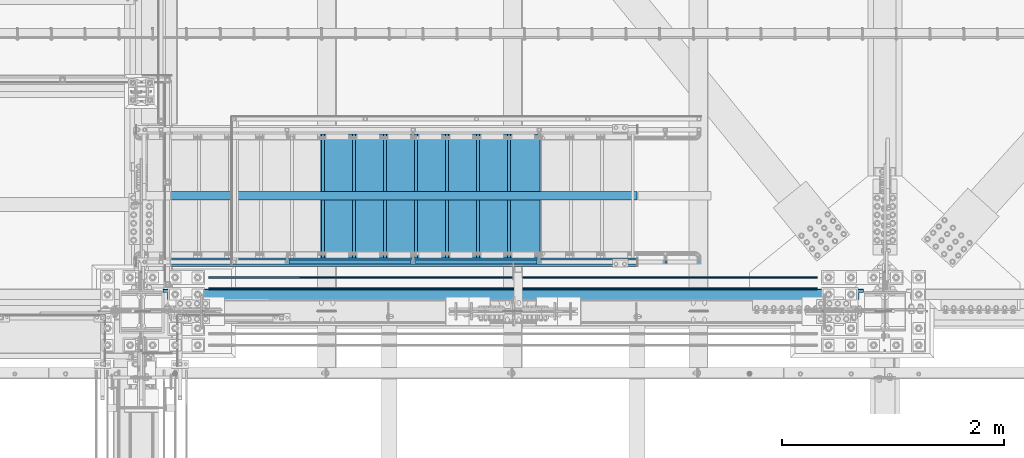
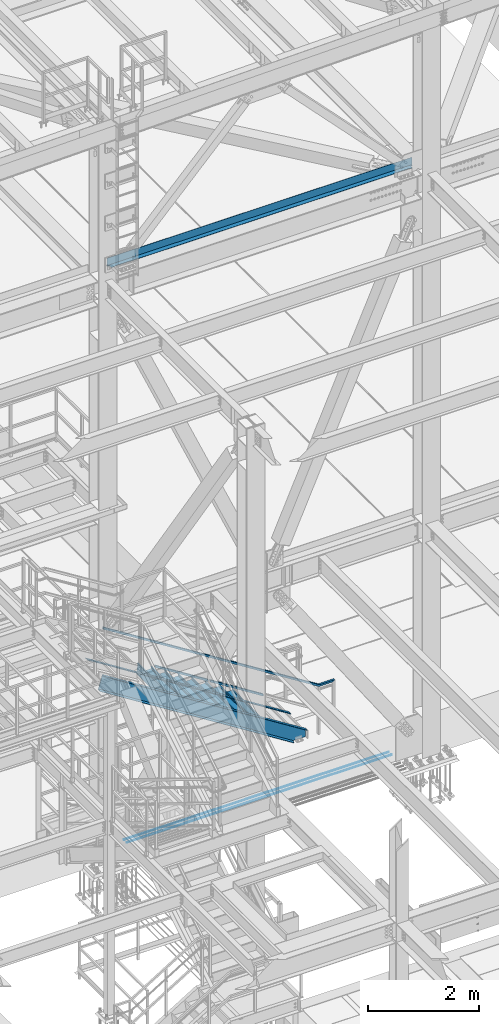
# One storey, part 1789 of 3843: 11 beams, 4 members, 6 elements without a shape of their own.
"""IFC2X3 building model written with IfcOpenShell, lengths in millimetres."""

import ifcopenshell
import ifcopenshell.guid

model = None  # the IFC model being written
_history = None  # IfcOwnerHistory: only IFC2X3 demands one
_inside = {}  # id of a spatial element -> (the spatial element, [elements in it])
_under = {}  # id of a project, library or spatial element -> (it, [spatial elements below it])
_declared = {}  # id of a project -> (the project, [libraries it declares])
_typed = {}  # id of a type object -> (the type object, [elements of that type])
_made_of = {}  # id of a material, layer set ... -> (it, [elements and type objects made of it])


def new_model(schema):
    """Start an empty IFC model of exactly this schema.

    Asked for "IFC4X3", IfcOpenShell would pick the latest addendum, in which some entities
    have other attributes; the version numbers below select the first issue.
    IFC2X3 requires an IfcOwnerHistory on every rooted entity: one is made here for all.
    """
    global model, _history
    if schema == "IFC4X3":
        model = ifcopenshell.file(schema_version=(4, 3, 0, 0))
    else:
        model = ifcopenshell.file(schema=schema)
    _inside.clear()
    _under.clear()
    _declared.clear()
    _typed.clear()
    _made_of.clear()
    _history = None
    if model.schema == "IFC2X3":
        org = make("IfcOrganization", Name="unknown")
        user = make(
            "IfcPersonAndOrganization",
            ThePerson=make("IfcPerson", FamilyName="unknown"),
            TheOrganization=org,
        )
        app = make(
            "IfcApplication",
            ApplicationDeveloper=org,
            Version="unknown",
            ApplicationFullName="unknown",
            ApplicationIdentifier="unknown",
        )
        _history = make(
            "IfcOwnerHistory",
            OwningUser=user,
            OwningApplication=app,
            ChangeAction="ADDED",
            CreationDate=0,
        )
    return model


def make(cls, **values):
    """One entity of the class cls with the attributes given. An attribute that is None is left unset."""
    return model.create_entity(
        cls, **{name: value for name, value in values.items() if value is not None}
    )


def rooted(cls, **values):
    """An entity with a GlobalId (a new one), such as an element, a storey or a relation."""
    return make(cls, GlobalId=ifcopenshell.guid.new(), OwnerHistory=_history, **values)


def si_unit(unit_type, name, prefix=None):
    """IfcSIUnit, for example si_unit("LENGTHUNIT", "METRE", prefix="MILLI")."""
    return make("IfcSIUnit", UnitType=unit_type, Prefix=prefix, Name=name)


def assignment(units):
    """IfcUnitAssignment: the units of a project."""
    return None if units is None else make("IfcUnitAssignment", Units=units)


def point(xyz):
    """IfcCartesianPoint."""
    return None if xyz is None else make("IfcCartesianPoint", Coordinates=xyz)


def direction(xyz):
    """IfcDirection."""
    return None if xyz is None else make("IfcDirection", DirectionRatios=xyz)


def frame(location, z_axis=None, x_axis=None):
    """IfcAxis2Placement3D, a coordinate frame: its origin and axes. An axis left out is left unset."""
    return make(
        "IfcAxis2Placement3D",
        Location=point(location),
        Axis=direction(z_axis),
        RefDirection=direction(x_axis),
    )


def origin_with_axes():
    """The frame at (0, 0, 0) with the z axis (0, 0, 1) and the x axis (1, 0, 0) written out."""
    return frame((0.0, 0.0, 0.0), z_axis=(0.0, 0.0, 1.0), x_axis=(1.0, 0.0, 0.0))


def place(relative_to, where):
    """IfcLocalPlacement: puts the frame where relative to a parent placement (None: the world)."""
    return make(
        "IfcLocalPlacement", PlacementRelTo=relative_to, RelativePlacement=where
    )


def context(
    kind, dimensions, precision=None, world=None, true_north=None, identifier=None
):
    """IfcGeometricRepresentationContext, for example the 3D "Model" context."""
    return make(
        "IfcGeometricRepresentationContext",
        ContextIdentifier=identifier,
        ContextType=kind,
        CoordinateSpaceDimension=dimensions,
        Precision=precision,
        WorldCoordinateSystem=world,
        TrueNorth=true_north,
    )


def subcontext(parent, identifier, kind, view, scale=None):
    """IfcGeometricRepresentationSubContext, for example "Body" below "Model"."""
    return make(
        "IfcGeometricRepresentationSubContext",
        ContextIdentifier=identifier,
        ContextType=kind,
        ParentContext=parent,
        TargetScale=scale,
        TargetView=view,
    )


def project(units=None, contexts=None):
    """IfcProject with its units and contexts."""
    return rooted(
        "IfcProject",
        Name="project",
        RepresentationContexts=contexts,
        UnitsInContext=assignment(units),
    )


def spatial(cls, under=None, at=None, **own):
    """A site, building, storey or space (cls), placed at a placement, below another one or the project."""
    s = rooted(cls, ObjectPlacement=at, **own)
    if under is not None:
        _under.setdefault(under.id(), (under, []))[1].append(s)
    return s


def faces_of(points, faces, orient=None, outer=None):
    """IfcFace entities. A face is a list of loops; a loop is a list of indices into points, from 0.

    orient and outer hold one flag for each loop. By default every Orientation is true, the
    first loop of a face is its IfcFaceOuterBound and the others are IfcFaceBound.
    """
    made = []
    for i, loops in enumerate(faces):
        bounds = []
        for j, loop in enumerate(loops):
            is_outer = j == 0 if outer is None else outer[i][j]
            bounds.append(
                make(
                    "IfcFaceOuterBound" if is_outer else "IfcFaceBound",
                    Bound=make("IfcPolyLoop", Polygon=[points[k] for k in loop]),
                    Orientation=True if orient is None else orient[i][j],
                )
            )
        made.append(make("IfcFace", Bounds=bounds))
    return made


def faceted_brep(points, faces, orient=None, outer=None, voids=None):
    """IfcFacetedBrep: a solid bounded by flat faces; with voids (closed shells), ...WithVoids."""
    shared = [point(p) for p in points]
    hull = make("IfcClosedShell", CfsFaces=faces_of(shared, faces, orient, outer))
    if voids is None:
        return make("IfcFacetedBrep", Outer=hull)
    return make(
        "IfcFacetedBrepWithVoids",
        Outer=hull,
        Voids=[
            make(cls, CfsFaces=faces_of(shared, fs, o, b)) for cls, fs, o, b in voids
        ],
    )


def shape(context_of_items, identifier, shape_type, items):
    """IfcShapeRepresentation: the items that make up one representation, for example the "Body"."""
    return make(
        "IfcShapeRepresentation",
        ContextOfItems=context_of_items,
        RepresentationIdentifier=identifier,
        RepresentationType=shape_type,
        Items=items,
    )


def material(Name=None, Category=None):
    """IfcMaterial."""
    return make("IfcMaterial", Name=Name, Category=Category)


def made_of(thing, what):
    """Note that an element or type object is made of a material, layer set ...; save() writes the relation."""
    if what is not None:
        _made_of.setdefault(what.id(), (what, []))[1].append(thing)
    return thing


def type_object(cls, material=None, **own):
    """A type object (cls), such as IfcWallType, which elements share."""
    return made_of(rooted(cls, **own), material)


def element(
    cls,
    number,
    at=None,
    inside=None,
    cuts=None,
    type_object=None,
    material=None,
    context=None,
    identifier="Body",
    shape_type=None,
    held_by="IfcProductDefinitionShape",
    body=None,
    shapes=None,
    **own,
):
    """One element of the class cls, such as IfcWall. Its Tag is "e" and its number.

    at: its placement. inside: the storey or other place that contains it. cuts: it is an
    opening in that element (IfcRelVoidsElement). A single representation is given by context,
    identifier, shape_type and body (its items); several are given by shapes. held_by: the class
    of the entity that holds the representations. save() writes the other relations.
    """
    e = rooted(cls, Tag="e%d" % number, ObjectPlacement=at, **own)
    if body is not None:
        shapes = [shape(context, identifier, shape_type, body)]
    if shapes is not None:
        e.Representation = make(held_by, Representations=shapes)
    if inside is not None:
        _inside.setdefault(inside.id(), (inside, []))[1].append(e)
    if cuts is not None:
        rooted(
            "IfcRelVoidsElement", RelatingBuildingElement=cuts, RelatedOpeningElement=e
        )
    if type_object is not None:
        _typed.setdefault(type_object.id(), (type_object, []))[1].append(e)
    return made_of(e, material)


def aggregate(whole, parts):
    """IfcRelAggregates: a whole, such as a stair, and the parts it consists of."""
    return rooted("IfcRelAggregates", RelatingObject=whole, RelatedObjects=parts)


def save(model, path):
    """Write the relations noted so far, then the file.

    IfcRelAggregates (storeys below a building ...), IfcRelContainedInSpatialStructure (elements
    in a storey), IfcRelDefinesByType, IfcRelAssociatesMaterial and IfcRelDeclares: one each for
    every whole, place, type object, material and project.
    """
    for whole, parts in _under.values():
        aggregate(whole, parts)
    for where, things in _inside.values():
        rooted(
            "IfcRelContainedInSpatialStructure",
            RelatedElements=things,
            RelatingStructure=where,
        )
    for kind, things in _typed.values():
        rooted("IfcRelDefinesByType", RelatedObjects=things, RelatingType=kind)
    for what, things in _made_of.values():
        rooted("IfcRelAssociatesMaterial", RelatedObjects=things, RelatingMaterial=what)
    for by, libraries in _declared.values():
        rooted("IfcRelDeclares", RelatingContext=by, RelatedDefinitions=libraries)
    model.write(path)


model = new_model("IFC2X3")

# Units and contexts
model_context = context("Model", 3, precision=1e-05, world=origin_with_axes())
body_context = subcontext(model_context, "Body", "Model", "MODEL_VIEW")
ifc_project = project(units=[si_unit("LENGTHUNIT", "METRE", prefix="MILLI"), si_unit("AREAUNIT", "SQUARE_METRE"), si_unit("VOLUMEUNIT", "CUBIC_METRE"), si_unit("MASSUNIT", "GRAM", prefix="KILO"), si_unit("TIMEUNIT", "SECOND"), si_unit("PLANEANGLEUNIT", "RADIAN"), si_unit("SOLIDANGLEUNIT", "STERADIAN"), si_unit("THERMODYNAMICTEMPERATUREUNIT", "DEGREE_CELSIUS"), si_unit("LUMINOUSINTENSITYUNIT", "LUMEN")], contexts=[model_context])

# Site, building, storey
site_placement = place(None, origin_with_axes())
site = spatial("IfcSite", under=ifc_project, at=site_placement, CompositionType="ELEMENT")
building_placement = place(site_placement, origin_with_axes())
building = spatial("IfcBuilding", under=site, at=building_placement, Name="Undefined", CompositionType="ELEMENT")
storey_placement = place(building_placement, origin_with_axes())
storey = spatial("IfcBuildingStorey", under=building, at=storey_placement, Name="Undefined", CompositionType="ELEMENT", Elevation=0.0)

# Assembly, beam, members
assembly_1_placement = place(storey_placement, origin_with_axes())
assembly_1 = element("IfcElementAssembly", 1, at=assembly_1_placement, inside=storey, Name="RAIL", AssemblyPlace="NOTDEFINED", PredefinedType="RIGID_FRAME")
ifc_material_1 = material()
beam_type_1 = type_object("IfcBeamType", Name="HSS1-1/2X1-1/2X1/4", PredefinedType="NOTDEFINED")
beam_1_placement = place(assembly_1_placement, frame((56184.7999995645, 26060.40000005, 34366.2000003071), z_axis=(-0.533450437959022, 0.0, -0.845831324935018), x_axis=(0.845831324935018, 0.0, -0.533450437959022)))
beam_1 = element("IfcBeam", 2, at=beam_1_placement, type_object=beam_type_1, material=ifc_material_1, Name="RAIL", ObjectType="HSS1-1/2X1-1/2X1/4", context=body_context, shape_type="Brep", body=[
    faceted_brep([(-5.50550328531972, 19.0499992350015, -19.0499992347177), (-5.50550328531972, -19.0499992350015, -19.0499992347177), (5.50550332753846, -19.0499992350015, 19.0499992347031), (5.50550332753846, 19.0499992350015, 19.0499992347031), (-3.67033547026585, 12.6999993300014, -12.6999993298159), (3.67033551248824, 12.6999993300014, 12.6999993297941), (3.67033551248824, -12.6999993300014, 12.6999993297941), (-3.67033547026585, -12.6999993300014, -12.6999993298159), (5290.72002363061, -19.0499992350015, 19.0499989655946), (5290.72002363061, 19.0499992350015, 19.0499989655946), (5279.70901704712, 19.0499992350015, -19.0499995038263), (5279.70901704712, -19.0499992350015, -19.0499995038263), (5281.54418485728, -12.6999993300014, -12.6999995989245), (5281.54418485728, 12.6999993300014, -12.6999995989245), (5288.88485582045, 12.6999993300014, 12.6999990606928), (5288.88485582045, -12.6999993300014, 12.6999990606928), (5548.97476379322, 19.0499992350015, -188.871010251023), (5548.97476379322, -19.0499992350015, -188.871010251023), (5537.07305247765, -19.0499992350015, -136.320377196243), (5537.07305247765, 19.0499992350015, -136.320377196243), (5546.99114519064, -12.6999993300014, -180.112571187878), (5546.99114519064, 12.6999993300014, -180.112571187878), (5539.05667108022, 12.6999993300014, -145.078816259382), (5539.05667108022, -12.6999993300014, -145.078816259382)], [[[0, 1, 2, 3], [4, 5, 6, 7]], [[3, 2, 8, 9]], [[1, 0, 10, 11]], [[4, 7, 12, 13]], [[6, 5, 14, 15]], [[11, 10, 16, 17]], [[8, 2, 1, 11, 17, 18]], [[9, 8, 18, 19]], [[10, 0, 3, 9, 19, 16]], [[13, 12, 20, 21]], [[14, 5, 4, 13, 21, 22]], [[15, 14, 22, 23]], [[12, 7, 6, 15, 23, 20]], [[19, 18, 17, 16], [22, 21, 20, 23]]]),
])
member_type_1 = type_object("IfcMemberType", Name="HSS1-1/2X1-1/2X1/4", PredefinedType="NOTDEFINED")
member_1_placement = place(assembly_1_placement, frame((58381.8999999823, 26060.40000005, 32447.1289770913), z_axis=(0.533450437959022, 0.0, 0.845831324935018), x_axis=(-0.845831324935018, 0.0, 0.533450437959022)))
member_1 = element("IfcMember", 3, at=member_1_placement, type_object=member_type_1, material=ifc_material_1, Name="RAIL", ObjectType="HSS1-1/2X1-1/2X1/4", context=body_context, shape_type="Brep", body=[
    faceted_brep([(1333.31811817363, -19.0500003825, 19.049999236413), (1309.28914186234, -19.0499992350015, -19.0499992335972), (1309.28914186234, 19.0499992350015, -19.0499992335972), (1333.31811817363, 19.0499992350015, 19.049999236413), (1329.31328868799, -12.6999993300014, 12.6999993314093), (1329.31328868799, 12.6999993300014, 12.6999993314093), (1313.29397134907, 12.6999993300014, -12.6999993285935), (1313.29397134907, -12.6999993300014, -12.6999993285935), (10.507732870894, 19.0499992350015, -19.049999235016), (34.5367091819608, 19.0499992350015, 19.0499992349214), (34.5367091819608, -19.0500003825, 19.0499992349214), (10.507732870894, -19.0499992350015, -19.049999235016), (30.5318796958745, -12.6999993300014, 12.699999329925), (14.5125623569802, -12.6999993300014, -12.6999993300269), (14.5125623569802, 12.6999993300014, -12.6999993300269), (30.5318796958745, 12.6999993300014, 12.699999329925)], [[[0, 1, 2, 3], [4, 5, 6, 7]], [[8, 9, 3, 2]], [[9, 10, 0, 3]], [[10, 11, 1, 0]], [[11, 8, 2, 1]], [[10, 9, 8, 11], [12, 13, 14, 15]], [[13, 12, 4, 7]], [[14, 13, 7, 6]], [[15, 14, 6, 5]], [[12, 15, 5, 4]]]),
])
member_2_placement = place(assembly_1_placement, frame((59518.5499999929, 26060.40000005, 31730.2644883423), z_axis=(0.533450437959022, 0.0, 0.845831324935018), x_axis=(-0.845831324935018, 0.0, 0.533450437959022)))
member_2 = element("IfcMember", 4, at=member_2_placement, type_object=member_type_1, material=ifc_material_1, Name="RAIL", ObjectType="HSS1-1/2X1-1/2X1/4", context=body_context, shape_type="Brep", body=[
    faceted_brep([(1333.31811817363, -19.0500003825, 19.049999236413), (1309.28914186234, -19.0499992350015, -19.0499992335972), (1309.28914186234, 19.0499992350015, -19.0499992335972), (1333.31811817363, 19.0499992350015, 19.049999236413), (1329.31328868799, -12.6999993300014, 12.6999993314093), (1329.31328868799, 12.6999993300014, 12.6999993314093), (1313.29397134907, 12.6999993300014, -12.6999993285935), (1313.29397134907, -12.6999993300014, -12.6999993285935), (10.507732870894, 19.0499992350015, -19.049999235016), (34.5367091819608, 19.0499992350015, 19.0499992349214), (34.5367091819608, -19.0500003825, 19.0499992349214), (10.507732870894, -19.0499992350015, -19.049999235016), (30.5318796958745, -12.6999993300014, 12.699999329925), (14.5125623569802, -12.6999993300014, -12.6999993300269), (14.5125623569802, 12.6999993300014, -12.6999993300269), (30.5318796958745, 12.6999993300014, 12.699999329925)], [[[0, 1, 2, 3], [4, 5, 6, 7]], [[8, 9, 3, 2]], [[9, 10, 0, 3]], [[10, 11, 1, 0]], [[11, 8, 2, 1]], [[10, 9, 8, 11], [12, 13, 14, 15]], [[13, 12, 4, 7]], [[14, 13, 7, 6]], [[15, 14, 6, 5]], [[12, 15, 5, 4]]]),
])
aggregate(assembly_1, [beam_1, member_1, member_2])

# Assembly, member
assembly_2_placement = place(storey_placement, origin_with_axes())
assembly_2 = element("IfcElementAssembly", 5, at=assembly_2_placement, inside=storey, Name="STAIR", AssemblyPlace="NOTDEFINED", PredefinedType="RIGID_FRAME")
ifc_material_2 = material(Name="STEEL/A36")
member_type_2 = type_object("IfcMemberType", Name="C12X20.7", PredefinedType="NOTDEFINED")
member_3_placement = place(assembly_2_placement, frame((56110.842824609, 26060.4000000759, 33195.8953060768), z_axis=(0.533450437959022, 0.0, 0.845831324935018), x_axis=(0.845831324935018, 0.0, -0.533450437959022)))
member_3 = element("IfcMember", 6, at=member_3_placement, type_object=member_type_2, material=ifc_material_2, Name="STAIR", ObjectType="C12X20.7", context=body_context, shape_type="Brep", body=[
    faceted_brep([(88.0880557814089, -38.0999999999985, -152.400000000001), (86.2521538732108, -38.0999999999985, -146.047460000002), (82.9654600282593, 30.1624999999985, -134.674927499997), (5.12259516357881, 30.1624999999985, 134.674927499997), (1.83590131863457, -38.0999999999985, 146.047460000002), (0.0, -38.0999999999985, 152.400000000001), (0.0, 38.0999999999985, 152.400000000001), (88.0880557814089, 38.0999999999985, -152.400000000001), (4825.73530544251, 38.0999999999985, -152.399999990193), (4825.73530544251, -38.0999999999985, -152.399999990193), (4835.807801297, -38.0999999999985, -146.047459990179), (4853.83992489816, 30.1624999999985, -134.674927490145), (5070.93921401628, 30.1624999999985, 2.24564691580599), (4987.41847453906, 30.1624999999985, 134.674927510001), (4980.24602506365, -38.0999999999985, 146.047460009984), (4976.23959358582, -38.0999999999985, 152.400000009977), (4976.23959358582, 38.0999999999985, 152.400000009977), (5070.93921401628, 38.0999999999985, 2.24564691580599)], [[[0, 1, 2, 3, 4, 5, 6, 7]], [[0, 7, 8, 9]], [[1, 0, 9, 10]], [[2, 1, 10, 11]], [[3, 2, 11, 12, 13]], [[4, 3, 13, 14]], [[5, 4, 14, 15]], [[6, 5, 15, 16]], [[8, 7, 6, 16, 17]], [[11, 10, 9, 8, 17, 12]], [[16, 15, 14, 13, 12, 17]]]),
])

# Assembly, beam
assembly_3_placement = place(storey_placement, origin_with_axes())
assembly_3 = element("IfcElementAssembly", 7, at=assembly_3_placement, inside=storey, Name="REBAR", AssemblyPlace="NOTDEFINED", PredefinedType="RIGID_FRAME")
ifc_material_3 = material(Name="STEEL/A706-60")
beam_type_2 = type_object("IfcBeamType", Name="#10 REBAR", PredefinedType="NOTDEFINED")
beam_2_placement = place(assembly_3_placement, frame((56540.3999804674, 25920.7000122071, 29687.8375), z_axis=(0.0, 0.0, 1.0), x_axis=(1.0, 0.0, 0.0)))
beam_2 = element("IfcBeam", 8, at=beam_2_placement, type_object=beam_type_2, material=ifc_material_3, Name="REBAR", ObjectType="#10 REBAR", context=body_context, shape_type="Brep", body=[
    faceted_brep([(0.0, -7.9375, 0.0), (0.0, -5.61266007566883, -5.61266007566883), (5486.48749999408, -5.61266007566883, -5.61266007566883), (5486.48749999408, -7.9375, 0.0), (0.0, 0.0, -7.9375), (5486.48749999408, 0.0, -7.9375), (0.0, 5.61266007566883, -5.61266007566883), (5486.48749999408, 5.61266007566883, -5.61266007566883), (0.0, 7.9375, 0.0), (5486.48749999408, 7.9375, 0.0), (0.0, 5.61266007566883, 5.61266007566883), (5486.48749999408, 5.61266007566883, 5.61266007566883), (0.0, 0.0, 7.9375), (5486.48749999408, 0.0, 7.9375), (0.0, -5.61266007566883, 5.61266007566883), (5486.48749999408, -5.61266007566883, 5.61266007566883)], [[[0, 1, 2, 3]], [[1, 4, 5, 2]], [[4, 6, 7, 5]], [[6, 8, 9, 7]], [[8, 10, 11, 9]], [[10, 12, 13, 11]], [[12, 14, 15, 13]], [[14, 0, 3, 15]], [[5, 7, 9, 11, 13, 15, 3, 2]], [[14, 12, 10, 8, 6, 4, 1, 0]]]),
])
aggregate(assembly_3, [beam_2])

assembly_4_placement = place(storey_placement, origin_with_axes())
assembly_4 = element("IfcElementAssembly", 9, at=assembly_4_placement, inside=storey, Name="REBAR", AssemblyPlace="NOTDEFINED", PredefinedType="RIGID_FRAME")
beam_3_placement = place(assembly_4_placement, frame((56540.3999804674, 25819.1000122071, 29687.8375), z_axis=(0.0, 0.0, 1.0), x_axis=(1.0, 0.0, 0.0)))
beam_3 = element("IfcBeam", 10, at=beam_3_placement, type_object=beam_type_2, material=ifc_material_3, Name="REBAR", ObjectType="#10 REBAR", context=body_context, shape_type="Brep", body=[
    faceted_brep([(0.0, -7.9375, 0.0), (0.0, -5.61266007566883, -5.61266007566883), (5486.48749999408, -5.61266007566883, -5.61266007566883), (5486.48749999408, -7.9375, 0.0), (0.0, 0.0, -7.9375), (5486.48749999408, 0.0, -7.9375), (0.0, 5.61266007566883, -5.61266007566883), (5486.48749999408, 5.61266007566883, -5.61266007566883), (0.0, 7.9375, 0.0), (5486.48749999408, 7.9375, 0.0), (0.0, 5.61266007566883, 5.61266007566883), (5486.48749999408, 5.61266007566883, 5.61266007566883), (0.0, 0.0, 7.9375), (5486.48749999408, 0.0, 7.9375), (0.0, -5.61266007566883, 5.61266007566883), (5486.48749999408, -5.61266007566883, 5.61266007566883)], [[[0, 1, 2, 3]], [[1, 4, 5, 2]], [[4, 6, 7, 5]], [[6, 8, 9, 7]], [[8, 10, 11, 9]], [[10, 12, 13, 11]], [[12, 14, 15, 13]], [[14, 0, 3, 15]], [[5, 7, 9, 11, 13, 15, 3, 2]], [[14, 12, 10, 8, 6, 4, 1, 0]]]),
])
aggregate(assembly_4, [beam_3])

# Assembly, member
assembly_5_placement = place(storey_placement, origin_with_axes())
assembly_5 = element("IfcElementAssembly", 11, at=assembly_5_placement, inside=storey, Name="ref.", AssemblyPlace="NOTDEFINED", PredefinedType="RIGID_FRAME")
ifc_material_4 = material(Name="STEEL/Steel_Undefined")
member_type_3 = type_object("IfcMemberType", PredefinedType="NOTDEFINED")
member_4_placement = place(assembly_5_placement, frame((60399.5062948593, 26657.30000005, 30667.5372949473), z_axis=(0.0, -1.0, 0.0), x_axis=(-0.845831324935018, 0.0, 0.533450437959022)))
member_4 = element("IfcMember", 12, at=member_4_placement, type_object=member_type_3, material=ifc_material_4, Name="ref.", context=body_context, shape_type="Brep", body=[
    faceted_brep([(0.0, 3.17500000000291, -38.0999999999985), (0.0, 3.17500000000291, 38.0999999999985), (4976.23959358166, 3.17499999472784, 38.0999999999985), (4976.23959358166, 3.17499999472784, -38.0999999999985), (0.0, -3.17500000000291, 38.0999999999985), (4976.23959358167, -3.17500000526343, 38.0999999999985), (0.0, -3.17500000000291, -38.0999999999985), (4976.23959358167, -3.17500000526343, -38.0999999999985)], [[[0, 1, 2, 3]], [[1, 4, 5, 2]], [[4, 6, 7, 5]], [[6, 0, 3, 7]], [[5, 7, 3, 2]], [[6, 4, 1, 0]]]),
])
aggregate(assembly_5, [member_4])

# Beam
ifc_material_5 = material(Name="STEEL/ASTM A1011")
beam_type_3 = type_object("IfcBeamType", PredefinedType="NOTDEFINED")
beam_4_placement = place(assembly_2_placement, frame((57556.4000000119, 26657.3000000423, 32416.7499999819), z_axis=(0.0, 1.0, 0.0), x_axis=(1.0, 0.0, 0.0)))
beam_4 = element("IfcBeam", 13, at=beam_4_placement, type_object=beam_type_3, material=ifc_material_5, Name="TREAD", context=body_context, shape_type="Brep", body=[
    faceted_brep([(0.0, -1.58750000000146, -558.799999999999), (0.0, -1.58750000000146, 558.799999999999), (0.0, 1.58750000000146, 558.799999999999), (0.0, 1.58750000000146, -558.799999999999), (21.7345275870466, 1.58750000000146, 558.799999999999), (21.7345275870466, 1.58750000000146, -558.799999999999), (25.3999999999942, -1.58750000000146, -558.799999999999), (25.3999999999942, -1.58750000000146, 558.799999999999), (-10.9879949354727, 228.599999999999, 558.799999999999), (-10.9879949354727, 228.599999999999, -558.799999999999), (-7.32252251826139, 225.424999999996, -558.799999999999), (-7.32252251826139, 225.424999999996, 558.799999999999), (293.812005064523, 228.599999999999, 558.799999999999), (293.812005064523, 228.599999999999, -558.799999999999), (291.061847962628, 225.424999999996, -558.799999999999), (291.061847962628, 225.424999999996, 558.799999999999), (299.640080752673, 188.167724913437, 558.799999999999), (299.640080752673, 188.167724913437, -558.799999999999), (296.49755982936, 187.714748924496, 558.799999999999), (296.49755982936, 187.714748924496, -558.799999999999)], [[[0, 1, 2, 3]], [[3, 2, 4, 5]], [[1, 0, 6, 7]], [[5, 4, 8, 9]], [[7, 6, 10, 11]], [[9, 8, 12, 13]], [[11, 10, 14, 15]], [[13, 12, 16, 17]], [[12, 8, 4, 2, 1, 7, 11, 15, 18, 16]], [[15, 14, 19, 18]], [[14, 10, 6, 0, 3, 5, 9, 13, 17, 19]], [[18, 19, 17, 16]]]),
])

beam_5_placement = place(assembly_2_placement, frame((57835.8000000131, 26657.3000000409, 32240.5374999839), z_axis=(0.0, 1.0, 0.0), x_axis=(1.0, 0.0, 0.0)))
beam_5 = element("IfcBeam", 14, at=beam_5_placement, type_object=beam_type_3, material=ifc_material_5, Name="TREAD", context=body_context, shape_type="Brep", body=[
    faceted_brep([(0.0, -1.58750000000146, -558.799999999999), (0.0, -1.58750000000146, 558.799999999999), (0.0, 1.58750000000146, 558.799999999999), (0.0, 1.58750000000146, -558.799999999999), (21.7345275870466, 1.58750000000146, 558.799999999999), (21.7345275870466, 1.58750000000146, -558.799999999999), (25.3999999999942, -1.58750000000146, -558.799999999999), (25.3999999999942, -1.58750000000146, 558.799999999999), (-10.9879949354727, 228.599999999999, 558.799999999999), (-10.9879949354727, 228.599999999999, -558.799999999999), (-7.32252251826139, 225.424999999996, -558.799999999999), (-7.32252251826139, 225.424999999996, 558.799999999999), (293.812005064523, 228.599999999999, 558.799999999999), (293.812005064523, 228.599999999999, -558.799999999999), (291.061847962628, 225.424999999996, -558.799999999999), (291.061847962628, 225.424999999996, 558.799999999999), (299.640080752673, 188.167724913437, 558.799999999999), (299.640080752673, 188.167724913437, -558.799999999999), (296.49755982936, 187.714748924496, 558.799999999999), (296.49755982936, 187.714748924496, -558.799999999999)], [[[0, 1, 2, 3]], [[3, 2, 4, 5]], [[1, 0, 6, 7]], [[5, 4, 8, 9]], [[7, 6, 10, 11]], [[9, 8, 12, 13]], [[11, 10, 14, 15]], [[13, 12, 16, 17]], [[12, 8, 4, 2, 1, 7, 11, 15, 18, 16]], [[15, 14, 19, 18]], [[14, 10, 6, 0, 3, 5, 9, 13, 17, 19]], [[18, 19, 17, 16]]]),
])

beam_6_placement = place(assembly_2_placement, frame((58115.2000000145, 26657.3000000395, 32064.324999986), z_axis=(0.0, 1.0, 0.0), x_axis=(1.0, 0.0, 0.0)))
beam_6 = element("IfcBeam", 15, at=beam_6_placement, type_object=beam_type_3, material=ifc_material_5, Name="TREAD", context=body_context, shape_type="Brep", body=[
    faceted_brep([(0.0, -1.58750000000146, -558.799999999999), (0.0, -1.58750000000146, 558.799999999999), (0.0, 1.58750000000146, 558.799999999999), (0.0, 1.58750000000146, -558.799999999999), (21.7345275870466, 1.58750000000146, 558.799999999999), (21.7345275870466, 1.58750000000146, -558.799999999999), (25.3999999999942, -1.58750000000146, -558.799999999999), (25.3999999999942, -1.58750000000146, 558.799999999999), (-10.9879949354727, 228.599999999999, 558.799999999999), (-10.9879949354727, 228.599999999999, -558.799999999999), (-7.32252251826139, 225.424999999996, -558.799999999999), (-7.32252251826139, 225.424999999996, 558.799999999999), (293.812005064523, 228.599999999999, 558.799999999999), (293.812005064523, 228.599999999999, -558.799999999999), (291.061847962628, 225.424999999996, -558.799999999999), (291.061847962628, 225.424999999996, 558.799999999999), (299.640080752673, 188.167724913437, 558.799999999999), (299.640080752673, 188.167724913437, -558.799999999999), (296.49755982936, 187.714748924496, 558.799999999999), (296.49755982936, 187.714748924496, -558.799999999999)], [[[0, 1, 2, 3]], [[3, 2, 4, 5]], [[1, 0, 6, 7]], [[5, 4, 8, 9]], [[7, 6, 10, 11]], [[9, 8, 12, 13]], [[11, 10, 14, 15]], [[13, 12, 16, 17]], [[12, 8, 4, 2, 1, 7, 11, 15, 18, 16]], [[15, 14, 19, 18]], [[14, 10, 6, 0, 3, 5, 9, 13, 17, 19]], [[18, 19, 17, 16]]]),
])

beam_7_placement = place(assembly_2_placement, frame((58394.6000000158, 26657.3000000381, 31888.112499988), z_axis=(0.0, 1.0, 0.0), x_axis=(1.0, 0.0, 0.0)))
beam_7 = element("IfcBeam", 16, at=beam_7_placement, type_object=beam_type_3, material=ifc_material_5, Name="TREAD", context=body_context, shape_type="Brep", body=[
    faceted_brep([(0.0, -1.58750000000146, -558.799999999999), (0.0, -1.58750000000146, 558.799999999999), (0.0, 1.58750000000146, 558.799999999999), (0.0, 1.58750000000146, -558.799999999999), (21.7345275870466, 1.58750000000146, 558.799999999999), (21.7345275870466, 1.58750000000146, -558.799999999999), (25.3999999999942, -1.58750000000146, -558.799999999999), (25.3999999999942, -1.58750000000146, 558.799999999999), (-10.9879949354727, 228.599999999999, 558.799999999999), (-10.9879949354727, 228.599999999999, -558.799999999999), (-7.32252251826139, 225.424999999996, -558.799999999999), (-7.32252251826139, 225.424999999996, 558.799999999999), (293.812005064523, 228.599999999999, 558.799999999999), (293.812005064523, 228.599999999999, -558.799999999999), (291.061847962628, 225.424999999996, -558.799999999999), (291.061847962628, 225.424999999996, 558.799999999999), (299.640080752673, 188.167724913437, 558.799999999999), (299.640080752673, 188.167724913437, -558.799999999999), (296.49755982936, 187.714748924496, 558.799999999999), (296.49755982936, 187.714748924496, -558.799999999999)], [[[0, 1, 2, 3]], [[3, 2, 4, 5]], [[1, 0, 6, 7]], [[5, 4, 8, 9]], [[7, 6, 10, 11]], [[9, 8, 12, 13]], [[11, 10, 14, 15]], [[13, 12, 16, 17]], [[12, 8, 4, 2, 1, 7, 11, 15, 18, 16]], [[15, 14, 19, 18]], [[14, 10, 6, 0, 3, 5, 9, 13, 17, 19]], [[18, 19, 17, 16]]]),
])

beam_8_placement = place(assembly_2_placement, frame((58674.0000000171, 26657.3000000367, 31711.8999999901), z_axis=(0.0, 1.0, 0.0), x_axis=(1.0, 0.0, 0.0)))
beam_8 = element("IfcBeam", 17, at=beam_8_placement, type_object=beam_type_3, material=ifc_material_5, Name="TREAD", context=body_context, shape_type="Brep", body=[
    faceted_brep([(0.0, -1.58750000000146, -558.799999999999), (0.0, -1.58750000000146, 558.799999999999), (0.0, 1.58750000000146, 558.799999999999), (0.0, 1.58750000000146, -558.799999999999), (21.7345275870466, 1.58750000000146, 558.799999999999), (21.7345275870466, 1.58750000000146, -558.799999999999), (25.3999999999942, -1.58750000000146, -558.799999999999), (25.3999999999942, -1.58750000000146, 558.799999999999), (-10.9879949354727, 228.599999999999, 558.799999999999), (-10.9879949354727, 228.599999999999, -558.799999999999), (-7.32252251826139, 225.424999999996, -558.799999999999), (-7.32252251826139, 225.424999999996, 558.799999999999), (293.812005064523, 228.599999999999, 558.799999999999), (293.812005064523, 228.599999999999, -558.799999999999), (291.061847962628, 225.424999999996, -558.799999999999), (291.061847962628, 225.424999999996, 558.799999999999), (299.640080752673, 188.167724913437, 558.799999999999), (299.640080752673, 188.167724913437, -558.799999999999), (296.49755982936, 187.714748924496, 558.799999999999), (296.49755982936, 187.714748924496, -558.799999999999)], [[[0, 1, 2, 3]], [[3, 2, 4, 5]], [[1, 0, 6, 7]], [[5, 4, 8, 9]], [[7, 6, 10, 11]], [[9, 8, 12, 13]], [[11, 10, 14, 15]], [[13, 12, 16, 17]], [[12, 8, 4, 2, 1, 7, 11, 15, 18, 16]], [[15, 14, 19, 18]], [[14, 10, 6, 0, 3, 5, 9, 13, 17, 19]], [[18, 19, 17, 16]]]),
])

beam_9_placement = place(assembly_2_placement, frame((58953.4000000183, 26657.3000000354, 31535.6874999921), z_axis=(0.0, 1.0, 0.0), x_axis=(1.0, 0.0, 0.0)))
beam_9 = element("IfcBeam", 18, at=beam_9_placement, type_object=beam_type_3, material=ifc_material_5, Name="TREAD", context=body_context, shape_type="Brep", body=[
    faceted_brep([(0.0, -1.58750000000146, -558.799999999999), (0.0, -1.58750000000146, 558.799999999999), (0.0, 1.58750000000146, 558.799999999999), (0.0, 1.58750000000146, -558.799999999999), (21.7345275870466, 1.58750000000146, 558.799999999999), (21.7345275870466, 1.58750000000146, -558.799999999999), (25.3999999999942, -1.58750000000146, -558.799999999999), (25.3999999999942, -1.58750000000146, 558.799999999999), (-10.9879949354727, 228.599999999999, 558.799999999999), (-10.9879949354727, 228.599999999999, -558.799999999999), (-7.32252251826139, 225.424999999996, -558.799999999999), (-7.32252251826139, 225.424999999996, 558.799999999999), (293.812005064523, 228.599999999999, 558.799999999999), (293.812005064523, 228.599999999999, -558.799999999999), (291.061847962628, 225.424999999996, -558.799999999999), (291.061847962628, 225.424999999996, 558.799999999999), (299.640080752673, 188.167724913437, 558.799999999999), (299.640080752673, 188.167724913437, -558.799999999999), (296.49755982936, 187.714748924496, 558.799999999999), (296.49755982936, 187.714748924496, -558.799999999999)], [[[0, 1, 2, 3]], [[3, 2, 4, 5]], [[1, 0, 6, 7]], [[5, 4, 8, 9]], [[7, 6, 10, 11]], [[9, 8, 12, 13]], [[11, 10, 14, 15]], [[13, 12, 16, 17]], [[12, 8, 4, 2, 1, 7, 11, 15, 18, 16]], [[15, 14, 19, 18]], [[14, 10, 6, 0, 3, 5, 9, 13, 17, 19]], [[18, 19, 17, 16]]]),
])

beam_10_placement = place(assembly_2_placement, frame((59232.8000000195, 26657.300000034, 31359.4749999941), z_axis=(0.0, 1.0, 0.0), x_axis=(1.0, 0.0, 0.0)))
beam_10 = element("IfcBeam", 19, at=beam_10_placement, type_object=beam_type_3, material=ifc_material_5, Name="TREAD", context=body_context, shape_type="Brep", body=[
    faceted_brep([(0.0, -1.58750000000146, -558.799999999999), (0.0, -1.58750000000146, 558.799999999999), (0.0, 1.58750000000146, 558.799999999999), (0.0, 1.58750000000146, -558.799999999999), (21.7345275870466, 1.58750000000146, 558.799999999999), (21.7345275870466, 1.58750000000146, -558.799999999999), (25.3999999999942, -1.58750000000146, -558.799999999999), (25.3999999999942, -1.58750000000146, 558.799999999999), (-10.9879949354727, 228.599999999999, 558.799999999999), (-10.9879949354727, 228.599999999999, -558.799999999999), (-7.32252251826139, 225.424999999996, -558.799999999999), (-7.32252251826139, 225.424999999996, 558.799999999999), (293.812005064523, 228.599999999999, 558.799999999999), (293.812005064523, 228.599999999999, -558.799999999999), (291.061847962628, 225.424999999996, -558.799999999999), (291.061847962628, 225.424999999996, 558.799999999999), (299.640080752673, 188.167724913437, 558.799999999999), (299.640080752673, 188.167724913437, -558.799999999999), (296.49755982936, 187.714748924496, 558.799999999999), (296.49755982936, 187.714748924496, -558.799999999999)], [[[0, 1, 2, 3]], [[3, 2, 4, 5]], [[1, 0, 6, 7]], [[5, 4, 8, 9]], [[7, 6, 10, 11]], [[9, 8, 12, 13]], [[11, 10, 14, 15]], [[13, 12, 16, 17]], [[12, 8, 4, 2, 1, 7, 11, 15, 18, 16]], [[15, 14, 19, 18]], [[14, 10, 6, 0, 3, 5, 9, 13, 17, 19]], [[18, 19, 17, 16]]]),
])

aggregate(assembly_2, [beam_4, beam_5, beam_6, beam_7, beam_8, beam_9, beam_10, member_3])

# Assembly, beam
assembly_6_placement = place(storey_placement, origin_with_axes())
assembly_6 = element("IfcElementAssembly", 20, at=assembly_6_placement, inside=storey, Name="BENT_PLATE", AssemblyPlace="NOTDEFINED", PredefinedType="RIGID_FRAME")
beam_type_4 = type_object("IfcBeamType", PredefinedType="NOTDEFINED")
beam_11_placement = place(assembly_6_placement, frame((59284.394, 25720.674999998, 42471.975), z_axis=(-1.0, 0.0, 0.0), x_axis=(0.0, 1.0, 0.0)))
beam_11 = element("IfcBeam", 21, at=beam_11_placement, type_object=beam_type_4, material=ifc_material_2, Name="BENT_PLATE", context=body_context, shape_type="Brep", body=[
    faceted_brep([(66.6750000019856, -3.17500000000291, 3120.23099999999), (66.6750000019856, 3.17500000000291, 3120.23099999999), (0.0, 3.17500000000291, 3120.231), (0.0, -3.17500000000291, 3120.231), (66.675000001982, -3.17500000000291, 3158.33099999998), (66.675000001982, 3.17500000000291, 3158.3315), (0.0, -3.17500000000291, 3048.0002499995), (0.0, 3.17500000000291, 3048.0002499995), (9.52500041729581, 3.17500000000291, 3048.0002499995), (9.52500041729581, -3.17500000000291, 3048.0002499995), (9.52500041726671, 3.17500000000291, 2730.5002499995), (9.52500041726671, -3.17500000000291, 2730.5002499995), (0.0, 3.17500000000291, 2730.5002499995), (0.0, -3.17500000000291, 2730.5002499995), (0.0, 3.17500000000291, -2730.49975000573), (0.0, -3.17500000000291, -2730.49975000573), (9.5250004173613, 3.17500000000291, -2730.49975000573), (9.5250004173613, -3.17500000000291, -2730.49975000573), (9.52500041733219, 3.17500000000291, -3047.99975000572), (9.52500041733219, -3.17500000000291, -3047.99975000572), (0.0, 3.17500000000291, -3047.99975000572), (0.0, -3.17500000000291, -3047.99975000572), (0.0, 3.17500000000291, -3120.23150000002), (0.0, -3.17500000000291, -3120.23150000002), (66.675000001982, 3.17500000000291, -3120.23150000002), (66.675000001982, -3.17500000000291, -3120.23150000002), (66.6750000019856, 3.17500000000291, -3158.3315), (66.6750000019856, -3.17500000000291, -3158.3315), (98.4250000020002, 3.17500000000291, -3158.3315), (98.4250000020002, -161.924999998002, -3158.3315), (92.0750000020016, -161.924999998002, -3158.3315), (92.0750000020016, -3.17500000000291, -3158.3315), (98.4250000020002, 3.17500000000291, 3158.3315), (98.4250000020002, -161.924999998002, 3158.3315), (92.0750000020016, -161.924999998002, 3158.3315), (92.0750000020016, -3.17500000000291, 3158.3315)], [[[0, 1, 2, 3]], [[4, 5, 1, 0]], [[6, 7, 8, 9]], [[9, 8, 10, 11]], [[11, 10, 12, 13]], [[14, 15, 13, 12]], [[15, 14, 16, 17]], [[17, 16, 18, 19]], [[19, 18, 20, 21]], [[21, 20, 22, 23]], [[23, 22, 24, 25]], [[25, 24, 26, 27]], [[28, 29, 30, 31, 27, 26]], [[28, 32, 33, 29]], [[34, 30, 29, 33]], [[35, 31, 30, 34]], [[3, 6, 9, 11, 13, 15, 17, 19, 21, 23, 25, 27, 31, 35, 4, 0]], [[7, 6, 3, 2]], [[32, 28, 26, 24, 22, 20, 18, 16, 14, 12, 10, 8, 7, 2, 1, 5]], [[35, 34, 33, 32, 5, 4]]]),
])
aggregate(assembly_6, [beam_11])

save(model, "model.ifc")
